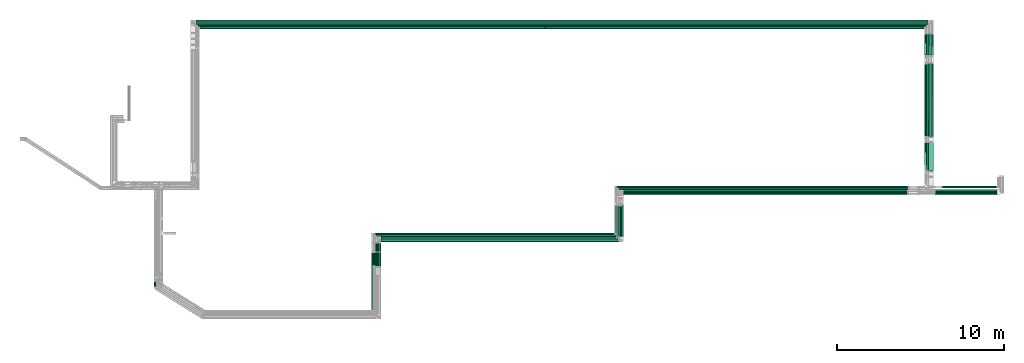
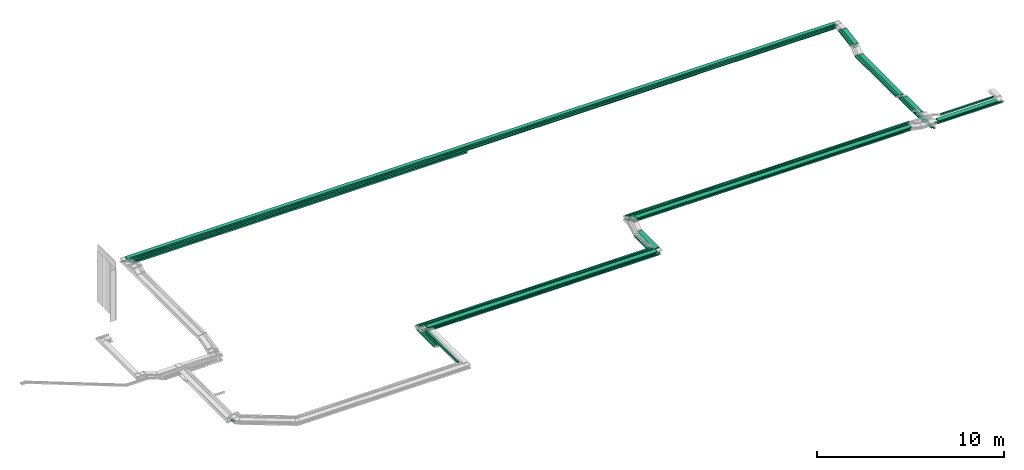
# One storey, part 2 of 18: 51 flow segments.
"""IFC2X3 building model written with IfcOpenShell, lengths in millimetres."""

from ifc_helpers import new_model, entity, si_unit, converted_unit, derived_unit, direction, frame, frame_2d, origin, origin_2d_with_axis, place, context, subcontext, project, spatial, rectangle, extrude, type_object, element, save


model = new_model("IFC2X3")

# Units and contexts
model_context = context("Model", 3, precision=0.01, world=origin(), true_north=direction((6.12303176911189e-17, 1.0)))
body_context = subcontext(model_context, "Body", "Model", "MODEL_VIEW")
ifc_project = project(units=[si_unit("LENGTHUNIT", "METRE", prefix="MILLI"), si_unit("AREAUNIT", "SQUARE_METRE"), si_unit("VOLUMEUNIT", "CUBIC_METRE"), converted_unit("PLANEANGLEUNIT", "DEGREE", entity("IfcRatioMeasure", 0.0174532925199433), si_unit("PLANEANGLEUNIT", "RADIAN"), dimensions=[0, 0, 0, 0, 0, 0, 0]), si_unit("MASSUNIT", "GRAM", prefix="KILO"), derived_unit("MASSDENSITYUNIT", [(si_unit("MASSUNIT", "GRAM", prefix="KILO"), 1), (si_unit("LENGTHUNIT", "METRE"), -3)]), derived_unit("MOMENTOFINERTIAUNIT", [(si_unit("LENGTHUNIT", "METRE"), 4)]), si_unit("TIMEUNIT", "SECOND"), si_unit("FREQUENCYUNIT", "HERTZ"), si_unit("THERMODYNAMICTEMPERATUREUNIT", "DEGREE_CELSIUS"), derived_unit("THERMALTRANSMITTANCEUNIT", [(si_unit("MASSUNIT", "GRAM", prefix="KILO"), 1), (si_unit("THERMODYNAMICTEMPERATUREUNIT", "KELVIN"), -1), (si_unit("TIMEUNIT", "SECOND"), -3)]), derived_unit("VOLUMETRICFLOWRATEUNIT", [(si_unit("LENGTHUNIT", "METRE"), 3), (si_unit("TIMEUNIT", "SECOND"), -1)]), derived_unit("MASSFLOWRATEUNIT", [(si_unit("MASSUNIT", "GRAM", prefix="KILO"), 1), (si_unit("TIMEUNIT", "SECOND"), -1)]), derived_unit("ROTATIONALFREQUENCYUNIT", [(si_unit("TIMEUNIT", "SECOND"), -1)]), si_unit("ELECTRICCURRENTUNIT", "AMPERE"), si_unit("ELECTRICVOLTAGEUNIT", "VOLT"), si_unit("POWERUNIT", "WATT"), si_unit("FORCEUNIT", "NEWTON", prefix="KILO"), si_unit("ILLUMINANCEUNIT", "LUX"), si_unit("LUMINOUSFLUXUNIT", "LUMEN"), si_unit("LUMINOUSINTENSITYUNIT", "CANDELA"), derived_unit("USERDEFINED", [(si_unit("MASSUNIT", "GRAM", prefix="KILO"), -1), (si_unit("LENGTHUNIT", "METRE"), -2), (si_unit("TIMEUNIT", "SECOND"), 3), (si_unit("LUMINOUSFLUXUNIT", "LUMEN"), 1)]), derived_unit("LINEARVELOCITYUNIT", [(si_unit("LENGTHUNIT", "METRE"), 1), (si_unit("TIMEUNIT", "SECOND"), -1)]), si_unit("PRESSUREUNIT", "PASCAL"), derived_unit("USERDEFINED", [(si_unit("LENGTHUNIT", "METRE"), -2), (si_unit("MASSUNIT", "GRAM", prefix="KILO"), 1), (si_unit("TIMEUNIT", "SECOND"), -2)]), derived_unit("LINEARFORCEUNIT", [(si_unit("MASSUNIT", "GRAM", prefix="KILO"), 1), (si_unit("LENGTHUNIT", "METRE"), 1), (si_unit("TIMEUNIT", "SECOND"), -2), (si_unit("LENGTHUNIT", "METRE"), -1)]), derived_unit("PLANARFORCEUNIT", [(si_unit("MASSUNIT", "GRAM", prefix="KILO"), 1), (si_unit("LENGTHUNIT", "METRE"), 1), (si_unit("TIMEUNIT", "SECOND"), -2), (si_unit("LENGTHUNIT", "METRE"), -2)])], contexts=[model_context])

# Site, building, storey
site_placement = place(None, frame((0.0, -0.00077364408347762, 0.0)))
site = spatial("IfcSite", under=ifc_project, at=site_placement, CompositionType="ELEMENT")
building_placement = place(site_placement, origin())
building = spatial("IfcBuilding", under=site, at=building_placement, CompositionType="ELEMENT")
storey_placement = place(building_placement, frame((0.0, 0.0, 19800.0)))
storey = spatial("IfcBuildingStorey", under=building, at=storey_placement, CompositionType="ELEMENT", Elevation=19800.0)

# Flow segments
cable_carrier_segment_type = type_object("IfcCableCarrierSegmentType", PredefinedType="CABLETRAYSEGMENT")
flow_segment_1_placement = place(storey_placement, frame((20510.216800265, 19700.0006393667, 3299.99856456245)))
element("IfcFlowSegment", 1, at=flow_segment_1_placement, inside=storey, type_object=cable_carrier_segment_type, context=body_context, shape_type="SweptSolid", body=[
    extrude(rectangle(XDim=43861.6970823392, YDim=300.000000000001, at=frame_2d((-3.63797880709171e-12, 2.17426077142591e-12), x_axis=(1.0, 0.0))), frame((21930.8485411696, 150.0, 0.000717718780356336), z_axis=(3.27264479763197e-08, 0.0, 1.0), x_axis=(-1.0, 0.0, 3.27264479763197e-08)), (0.0, 0.0, 1.0), 49.9999999999973),
])
flow_segment_2_placement = place(storey_placement, frame((20615.2168010831, 19595.0006393667, 3300.0)))
element("IfcFlowSegment", 2, at=flow_segment_2_placement, inside=storey, type_object=cable_carrier_segment_type, context=body_context, shape_type="SweptSolid", body=[
    extrude(rectangle(XDim=43650.3107133575, YDim=100.000000000003, at=frame_2d((-5.45696821063757e-12, -2.16715534406831e-12), x_axis=(1.0, 0.0))), frame((21825.1553566787, 50.0, 0.0), z_axis=(0.0, 0.0, 1.0), x_axis=(-1.0, 0.0, 0.0)), (0.0, 0.0, 1.0), 100.000000000003),
])
flow_segment_3_placement = place(storey_placement, frame((20720.2168010831, 19490.0006393667, 3300.0)))
element("IfcFlowSegment", 3, at=flow_segment_3_placement, inside=storey, type_object=cable_carrier_segment_type, context=body_context, shape_type="SweptSolid", body=[
    extrude(rectangle(XDim=43439.8425431613, YDim=100.000000000001, at=frame_2d((3.63797880709171e-12, -1.08357767203415e-12), x_axis=(1.0, 0.0))), frame((21719.9212715806, 50.0, 0.0), z_axis=(0.0, 0.0, 1.0), x_axis=(-1.0, 0.0, 0.0)), (0.0, 0.0, 1.0), 100.000000000003),
])
flow_segment_4_placement = place(storey_placement, frame((64593.0376989449, 9615.00063936669, 2550.0)))
element("IfcFlowSegment", 4, at=flow_segment_4_placement, inside=storey, type_object=cable_carrier_segment_type, context=body_context, shape_type="SweptSolid", body=[
    extrude(rectangle(XDim=7760.0992906484, YDim=99.9999999999946, at=frame_2d((0.0, -4.33075797445781e-12), x_axis=(1.0, 0.0))), frame((50.0, 3880.0496453242, 0.0), z_axis=(0.0, 0.0, 1.0), x_axis=(0.0, -1.0, 0.0)), (0.0, 0.0, 1.0), 49.9999999999973),
])
flow_segment_5_placement = place(storey_placement, frame((64490.5275144406, 9720.00063936033, 2550.0)))
element("IfcFlowSegment", 5, at=flow_segment_5_placement, inside=storey, type_object=cable_carrier_segment_type, context=body_context, shape_type="SweptSolid", body=[
    extrude(rectangle(XDim=7655.09929065903, YDim=99.9999999999946, at=frame_2d((0.0, -4.33075797445781e-12), x_axis=(1.0, 0.0))), frame((50.0, 3827.54964532952, 0.0), z_axis=(0.0, 0.0, 1.0), x_axis=(0.0, -1.0, 0.0)), (0.0, 0.0, 1.0), 49.9999999999973),
])
flow_segment_6_placement = place(storey_placement, frame((64388.5726926723, 10290.0006393667, 2550.0)))
element("IfcFlowSegment", 6, at=flow_segment_6_placement, inside=storey, type_object=cable_carrier_segment_type, context=body_context, shape_type="SweptSolid", body=[
    extrude(rectangle(XDim=7085.0992906527, YDim=99.9999999999946, at=frame_2d((-9.09494701772928e-13, 0.0), x_axis=(1.0, 0.0))), frame((50.0, 3542.54964532635, 0.0), z_axis=(0.0, 0.0, 1.0), x_axis=(0.0, -1.0, 0.0)), (0.0, 0.0, 1.0), 49.9999999999973),
])
flow_segment_7_placement = place(storey_placement, frame((20720.2168010831, 19490.0006393668, 3100.0)))
element("IfcFlowSegment", 7, at=flow_segment_7_placement, inside=storey, type_object=cable_carrier_segment_type, context=body_context, shape_type="SweptSolid", body=[
    extrude(rectangle(XDim=20698.7834674717, YDim=100.000000000001, at=frame_2d((0.0, 1.08357767203415e-12), x_axis=(1.0, 0.0))), frame((10349.3917337358, 50.0, 0.0), z_axis=(0.0, 0.0, 1.0), x_axis=(-1.0, 0.0, 0.0)), (0.0, 0.0, 1.0), 100.000000000003),
])
flow_segment_8_placement = place(storey_placement, frame((20310.2168010831, 19900.0006393667, 3100.0)))
element("IfcFlowSegment", 8, at=flow_segment_8_placement, inside=storey, type_object=cable_carrier_segment_type, context=body_context, shape_type="SweptSolid", body=[
    extrude(rectangle(XDim=44262.8208978618, YDim=100.000000000003, at=frame_2d((0.0, 2.16715534406831e-12), x_axis=(1.0, 0.0))), frame((22131.4104489309, 50.0, 0.0), z_axis=(0.0, 0.0, 1.0), x_axis=(-1.0, 0.0, 0.0)), (0.0, 0.0, 1.0), 49.9999999999973),
])
flow_segment_9_placement = place(storey_placement, frame((20415.2168010831, 19795.0006393667, 3100.0)))
element("IfcFlowSegment", 9, at=flow_segment_9_placement, inside=storey, type_object=cable_carrier_segment_type, context=body_context, shape_type="SweptSolid", body=[
    extrude(rectangle(XDim=44055.3107133575, YDim=100.000000000003, at=frame_2d((-3.63797880709171e-12, 2.16715534406831e-12), x_axis=(1.0, 0.0))), frame((22027.6553566787, 50.0, 0.0), z_axis=(0.0, 0.0, 1.0), x_axis=(-1.0, 0.0, 0.0)), (0.0, 0.0, 1.0), 49.9999999999973),
])
flow_segment_10_placement = place(storey_placement, frame((20520.2168010831, 19690.0006393667, 3100.0)))
element("IfcFlowSegment", 10, at=flow_segment_10_placement, inside=storey, type_object=cable_carrier_segment_type, context=body_context, shape_type="SweptSolid", body=[
    extrude(rectangle(XDim=43848.3558915892, YDim=100.000000000003, at=frame_2d((0.0, 2.16715534406831e-12), x_axis=(1.0, 0.0))), frame((21924.1779457946, 50.0, 0.0), z_axis=(0.0, 0.0, 1.0), x_axis=(-1.0, 0.0, 0.0)), (0.0, 0.0, 1.0), 49.9999999999973),
])
flow_segment_11_placement = place(storey_placement, frame((46136.3862833498, 9515.00005292883, 3174.99999031633)))
element("IfcFlowSegment", 11, at=flow_segment_11_placement, inside=storey, type_object=cable_carrier_segment_type, context=body_context, shape_type="SweptSolid", body=[
    extrude(rectangle(XDim=17012.5626625772, YDim=300.000000000001, at=frame_2d((4.54747350886464e-12, 0.0), x_axis=(1.0, 0.0))), frame((8506.2813312886, 150.0, 1.41768531420894e-05), z_axis=(0.0, 6.09869900927148e-08, 1.0), x_axis=(-1.0, 0.0, 0.0)), (0.0, 0.0, 1.0), 50.0000000000017),
])
flow_segment_12_placement = place(storey_placement, frame((45715.1221386505, 9945.00008284563, 3175.0)))
element("IfcFlowSegment", 12, at=flow_segment_12_placement, inside=storey, type_object=cable_carrier_segment_type, context=body_context, shape_type="SweptSolid", body=[
    extrude(rectangle(XDim=17558.63871242, YDim=99.9999999999989, at=origin_2d_with_axis()), frame((8779.31935621001, 50.0, 0.0), z_axis=(0.0, 0.0, 1.0), x_axis=(-1.0, 0.0, 0.0)), (0.0, 0.0, 1.0), 100.000000000003),
])
flow_segment_13_placement = place(storey_placement, frame((31591.4335639594, 6717.77902723853, 2800.0)))
element("IfcFlowSegment", 13, at=flow_segment_13_placement, inside=storey, type_object=cable_carrier_segment_type, context=body_context, shape_type="SweptSolid", body=[
    extrude(rectangle(XDim=14204.952720189, YDim=300.000000000001, at=origin_2d_with_axis()), frame((7102.47636009451, 150.0, 0.0), z_axis=(0.0, 0.0, 1.0), x_axis=(-1.0, 0.0, 0.0)), (0.0, 0.0, 1.0), 49.9999999999973),
])
flow_segment_14_placement = place(storey_placement, frame((31280.6071314255, 7021.9281801225, 2800.0)))
element("IfcFlowSegment", 14, at=flow_segment_14_placement, inside=storey, type_object=cable_carrier_segment_type, context=body_context, shape_type="SweptSolid", body=[
    extrude(rectangle(XDim=14408.678815753, YDim=100.000000000001, at=frame_2d((0.0, -5.43565192856477e-13), x_axis=(1.0, 0.0))), frame((7204.33940787652, 50.0, 0.0), z_axis=(0.0, 0.0, 1.0), x_axis=(-1.0, 0.0, 0.0)), (0.0, 0.0, 1.0), 100.000000000003),
])
flow_segment_15_placement = place(storey_placement, frame((31167.8922149001, 7125.0, 2800.0)))
element("IfcFlowSegment", 15, at=flow_segment_15_placement, inside=storey, type_object=cable_carrier_segment_type, context=body_context, shape_type="SweptSolid", body=[
    extrude(rectangle(XDim=14407.2299237504, YDim=100.000000000001, at=frame_2d((-4.54747350886464e-12, -5.43565192856477e-13), x_axis=(1.0, 0.0))), frame((7203.6149618752, 50.0, 0.0), z_axis=(0.0, 0.0, 1.0), x_axis=(-1.0, 0.0, 0.0)), (0.0, 0.0, 1.0), 100.000000000003),
])
flow_segment_16_placement = place(storey_placement, frame((31591.4335639594, 6717.77902723852, 2600.0)))
element("IfcFlowSegment", 16, at=flow_segment_16_placement, inside=storey, type_object=cable_carrier_segment_type, context=body_context, shape_type="SweptSolid", body=[
    extrude(rectangle(XDim=14323.3274230858, YDim=99.9999999999989, at=frame_2d((-2.27373675443232e-12, 5.40012479177676e-13), x_axis=(1.0, 0.0))), frame((7161.66371154289, 50.0, 0.0), z_axis=(0.0, 0.0, 1.0), x_axis=(-1.0, 0.0, 0.0)), (0.0, 0.0, 1.0), 50.0000000000016),
])
flow_segment_17_placement = place(storey_placement, frame((31481.4991593832, 6822.77902723852, 2600.0)))
element("IfcFlowSegment", 17, at=flow_segment_17_placement, inside=storey, type_object=cable_carrier_segment_type, context=body_context, shape_type="SweptSolid", body=[
    extrude(rectangle(XDim=14320.0, YDim=99.9999999999989, at=frame_2d((2.27373675443232e-12, 0.0), x_axis=(1.0, 0.0))), frame((7160.0, 50.0, 0.0), z_axis=(0.0, 0.0, 1.0), x_axis=(-1.0, 0.0, 0.0)), (0.0, 0.0, 1.0), 49.9999999999973),
])
flow_segment_18_placement = place(storey_placement, frame((31369.2859471786, 6927.77902723852, 2600.0)))
element("IfcFlowSegment", 18, at=flow_segment_18_placement, inside=storey, type_object=cable_carrier_segment_type, context=body_context, shape_type="SweptSolid", body=[
    extrude(rectangle(XDim=14320.0, YDim=99.9999999999989, at=frame_2d((2.27373675443232e-12, 5.40012479177676e-13), x_axis=(1.0, 0.0))), frame((7160.0, 50.0, 0.0), z_axis=(0.0, 0.0, 1.0), x_axis=(-1.0, 0.0, 0.0)), (0.0, 0.0, 1.0), 49.9999999999973),
])
flow_segment_19_placement = place(storey_placement, frame((31245.1088789037, 7125.0, 2600.0)))
element("IfcFlowSegment", 19, at=flow_segment_19_placement, inside=storey, type_object=cable_carrier_segment_type, context=body_context, shape_type="SweptSolid", body=[
    extrude(rectangle(XDim=14330.0132597468, YDim=99.9999999999989, at=frame_2d((1.81898940354586e-12, -1.08357767203415e-12), x_axis=(1.0, 0.0))), frame((7165.00662987341, 50.0, 0.0), z_axis=(0.0, 0.0, 1.0), x_axis=(-1.0, 0.0, 0.0)), (0.0, 0.0, 1.0), 100.000000000003),
])
flow_segment_20_placement = place(storey_placement, frame((64391.9138834223, 17890.7715456811, 3082.61086731143)))
element("IfcFlowSegment", 20, at=flow_segment_20_placement, inside=storey, type_object=cable_carrier_segment_type, context=body_context, shape_type="SweptSolid", body=[
    extrude(rectangle(XDim=49.9999999999963, YDim=1283.81748851725, at=frame_2d((-1.08002495835535e-12, 1.86517468137026e-13), x_axis=(0.0, 1.0))), frame((0.0, 636.956556995006, 132.702158056389), z_axis=(1.0, 0.0, 0.0), x_axis=(0.0, -0.985728987268031, -0.168340023938282)), (0.0, 0.0, 1.0), 300.000000000001),
])
flow_segment_21_placement = place(storey_placement, frame((64285.5275144406, 17888.8603400682, 3083.36144550776)))
element("IfcFlowSegment", 21, at=flow_segment_21_placement, inside=storey, type_object=cable_carrier_segment_type, context=body_context, shape_type="SweptSolid", body=[
    extrude(rectangle(XDim=100.000000000001, YDim=99.9999999999946, at=frame_2d((-1.81188397618826e-13, 0.0), x_axis=(1.0, 0.0))), frame((50.0, 8.41700119691529, 49.2864493634023), z_axis=(0.0, 0.985728987268031, 0.168340023938282), x_axis=(0.0, -0.168340023938282, 0.985728987268031)), (0.0, 0.0, 1.0), 1277.24793927283),
])
flow_segment_22_placement = place(storey_placement, frame((64180.0593442443, 17888.8603400682, 3083.36144550776)))
element("IfcFlowSegment", 22, at=flow_segment_22_placement, inside=storey, type_object=cable_carrier_segment_type, context=body_context, shape_type="SweptSolid", body=[
    extrude(rectangle(XDim=100.000000000001, YDim=99.9999999999946, at=frame_2d((-1.81188397618826e-13, 0.0), x_axis=(1.0, 0.0))), frame((50.0, 8.41700119691313, 49.2864493634066), z_axis=(0.0, 0.985728987268031, 0.168340023938282), x_axis=(0.0, -0.168340023938282, 0.985728987268031)), (0.0, 0.0, 1.0), 1277.24793927283),
])
for number, where in (
    (23, (64593.0376989449, 17882.6287228456, 2877.80619248528)),
    (24, (64490.5275144406, 17882.6287228456, 2877.80619248528)),
    (25, (64388.5726926723, 17882.6287228456, 2877.80619248528)),
):
    element("IfcFlowSegment", number, at=place(storey_placement, frame(where)), inside=storey, type_object=cable_carrier_segment_type, context=body_context, shape_type="SweptSolid", body=[
        extrude(rectangle(XDim=49.9999999999963, YDim=1312.36750384491, at=frame_2d((0.0, 0.0), x_axis=(0.0, 1.0))), frame((0.0, 651.027845842717, 135.10521318823), z_axis=(1.0, 0.0, 0.0), x_axis=(0.0, -0.985728987268033, -0.168340023938271)), (0.0, 0.0, 1.0), 99.9999999999945),
    ])
flow_segment_23_placement = place(storey_placement, frame((64285.5467024828, 10981.4942885013, 2800.00365146292)))
element("IfcFlowSegment", 26, at=flow_segment_23_placement, inside=storey, type_object=cable_carrier_segment_type, context=body_context, shape_type="SweptSolid", body=[
    extrude(rectangle(XDim=1669.27622341284, YDim=99.999999999908, at=frame_2d((0.0, -4.33075797445781e-12), x_axis=(1.0, 0.0))), frame((50.0, 834.649123727306, 0.0919527997453315), z_axis=(0.0, -0.000110170861433383, 0.999999993931191), x_axis=(0.0, 0.999999993931191, 0.000110170861433383)), (0.0, 0.0, 1.0), 99.9999999999068),
])
flow_segment_24_placement = place(storey_placement, frame((64180.0597687348, 11289.128001488, 2800.00494189321)))
element("IfcFlowSegment", 27, at=flow_segment_24_placement, inside=storey, type_object=cable_carrier_segment_type, context=body_context, shape_type="SweptSolid", body=[
    extrude(rectangle(XDim=1361.64006742099, YDim=99.9999999999946, at=origin_2d_with_axis()), frame((50.0, 680.833403180097, 0.0910634902381617), z_axis=(0.0, -0.000133755597263879, 0.99999999105472), x_axis=(0.0, 0.99999999105472, 0.000133755597263879)), (0.0, 0.0, 1.0), 99.9999999999964),
])
flow_segment_25_placement = place(storey_placement, frame((64393.0376989449, 10968.0961382918, 2800.0)))
element("IfcFlowSegment", 28, at=flow_segment_25_placement, inside=storey, type_object=cable_carrier_segment_type, context=body_context, shape_type="SweptSolid", body=[
    extrude(rectangle(XDim=1687.04298934208, YDim=300.000000000001, at=frame_2d((-1.08002495835535e-12, 0.0), x_axis=(1.0, 0.0))), frame((150.0, 843.52149467104, 0.0), z_axis=(0.0, 0.0, 1.0), x_axis=(0.0, 1.0, 0.0)), (0.0, 0.0, 1.0), 49.9999999999973),
])
flow_segment_26_placement = place(storey_placement, frame((45595.1221386505, 7245.0, 2600.0)))
element("IfcFlowSegment", 29, at=flow_segment_26_placement, inside=storey, type_object=cable_carrier_segment_type, context=body_context, shape_type="SweptSolid", body=[
    extrude(rectangle(XDim=1580.56637967652, YDim=99.9999999999946, at=frame_2d((-5.6843418860808e-13, 0.0), x_axis=(1.0, 0.0))), frame((50.0, 790.28318983826, 0.0), z_axis=(0.0, 0.0, 1.0), x_axis=(0.0, 1.0, 0.0)), (0.0, 0.0, 1.0), 100.000000000003),
])
flow_segment_27_placement = place(storey_placement, frame((45709.2859471786, 7047.77902723852, 2600.0)))
element("IfcFlowSegment", 30, at=flow_segment_27_placement, inside=storey, type_object=cable_carrier_segment_type, context=body_context, shape_type="SweptSolid", body=[
    extrude(rectangle(XDim=1790.25375258002, YDim=99.9999999999946, at=origin_2d_with_axis()), frame((50.0, 895.126876290009, 0.0), z_axis=(0.0, 0.0, 1.0), x_axis=(0.0, 1.0, 0.0)), (0.0, 0.0, 1.0), 49.999999999993),
])
flow_segment_28_placement = place(storey_placement, frame((45821.4991593832, 6942.77902723852, 2600.0)))
element("IfcFlowSegment", 31, at=flow_segment_28_placement, inside=storey, type_object=cable_carrier_segment_type, context=body_context, shape_type="SweptSolid", body=[
    extrude(rectangle(XDim=1895.25375258002, YDim=99.9999999999946, at=frame_2d((0.0, 4.33075797445781e-12), x_axis=(1.0, 0.0))), frame((50.0, 947.626876290012, 0.0), z_axis=(0.0, 0.0, 1.0), x_axis=(0.0, 1.0, 0.0)), (0.0, 0.0, 1.0), 50.0000000000016),
])
flow_segment_29_placement = place(storey_placement, frame((45934.7609870451, 6837.77902723851, 2600.0)))
element("IfcFlowSegment", 32, at=flow_segment_29_placement, inside=storey, type_object=cable_carrier_segment_type, context=body_context, shape_type="SweptSolid", body=[
    extrude(rectangle(XDim=2000.25375258002, YDim=99.9999999999946, at=origin_2d_with_axis()), frame((50.0, 1000.12687629001, 0.0), z_axis=(0.0, 0.0, 1.0), x_axis=(0.0, 1.0, 0.0)), (0.0, 0.0, 1.0), 49.999999999993),
])
flow_segment_30_placement = place(storey_placement, frame((45816.3862841484, 7037.77902723852, 2800.0)))
element("IfcFlowSegment", 33, at=flow_segment_30_placement, inside=storey, type_object=cable_carrier_segment_type, context=body_context, shape_type="SweptSolid", body=[
    extrude(rectangle(XDim=1884.43926960423, YDim=300.000000000001, at=frame_2d((0.0, -4.33431068813661e-12), x_axis=(1.0, 0.0))), frame((150.0, 942.219634802116, 0.0), z_axis=(0.0, 0.0, 1.0), x_axis=(0.0, 1.0, 0.0)), (0.0, 0.0, 1.0), 49.9999999999973),
])
flow_segment_31_placement = place(storey_placement, frame((31125.1088789037, 5296.63362492178, 2600.0)))
element("IfcFlowSegment", 34, at=flow_segment_31_placement, inside=storey, type_object=cable_carrier_segment_type, context=body_context, shape_type="SweptSolid", body=[
    extrude(rectangle(XDim=1808.36637507826, YDim=100.000000000003, at=origin_2d_with_axis()), frame((50.0, 904.183187539129, 0.0), z_axis=(0.0, 0.0, 1.0), x_axis=(0.0, 1.0, 0.0)), (0.0, 0.0, 1.0), 100.000000000003),
])
flow_segment_32_placement = place(storey_placement, frame((31249.2859471786, 5245.16498530927, 2600.0)))
element("IfcFlowSegment", 35, at=flow_segment_32_placement, inside=storey, type_object=cable_carrier_segment_type, context=body_context, shape_type="SweptSolid", body=[
    extrude(rectangle(XDim=1662.61404192942, YDim=100.000000000003, at=frame_2d((-5.6843418860808e-13, -4.33431068813661e-12), x_axis=(1.0, 0.0))), frame((50.0, 831.307020964711, 0.0), z_axis=(0.0, 0.0, 1.0), x_axis=(0.0, -1.0, 0.0)), (0.0, 0.0, 1.0), 49.9999999999973),
])
flow_segment_33_placement = place(storey_placement, frame((31361.4991593832, 5245.16498530928, 2600.0)))
element("IfcFlowSegment", 36, at=flow_segment_33_placement, inside=storey, type_object=cable_carrier_segment_type, context=body_context, shape_type="SweptSolid", body=[
    extrude(rectangle(XDim=1557.61404192941, YDim=100.000000000003, at=frame_2d((-5.6843418860808e-13, 2.16715534406831e-12), x_axis=(1.0, 0.0))), frame((50.0, 778.807020964705, 0.0), z_axis=(0.0, 0.0, 1.0), x_axis=(0.0, -1.0, 0.0)), (0.0, 0.0, 1.0), 49.9999999999973),
])
flow_segment_34_placement = place(storey_placement, frame((31471.4335639594, 5245.16498530928, 2600.0)))
element("IfcFlowSegment", 37, at=flow_segment_34_placement, inside=storey, type_object=cable_carrier_segment_type, context=body_context, shape_type="SweptSolid", body=[
    extrude(rectangle(XDim=1452.61404192941, YDim=100.000000000003, at=frame_2d((-5.11590769747272e-13, 0.0), x_axis=(1.0, 0.0))), frame((50.0, 726.307020964705, 0.0), z_axis=(0.0, 0.0, 1.0), x_axis=(0.0, -1.0, 0.0)), (0.0, 0.0, 1.0), 49.9999999999973),
])
flow_segment_35_placement = place(storey_placement, frame((31047.8922149002, 2619.99989830113, 3200.0)))
element("IfcFlowSegment", 38, at=flow_segment_35_placement, inside=storey, type_object=cable_carrier_segment_type, context=body_context, shape_type="SweptSolid", body=[
    extrude(rectangle(XDim=3419.24047842777, YDim=100.000000000003, at=origin_2d_with_axis()), frame((50.0, 1709.62023921389, 0.0), z_axis=(0.0, 0.0, 1.0), x_axis=(0.0, 1.0, 0.0)), (0.0, 0.0, 1.0), 100.000000000008),
])
flow_segment_36_placement = place(storey_placement, frame((18007.1440474966, 4020.34867137986, 3000.0)))
element("IfcFlowSegment", 39, at=flow_segment_36_placement, inside=storey, type_object=cable_carrier_segment_type, context=body_context, shape_type="SweptSolid", body=[
    extrude(rectangle(XDim=303.89022785907, YDim=99.9999999999989, at=frame_2d((0.0, -1.08357767203415e-12), x_axis=(1.0, 0.0))), frame((50.0, 151.945113929536, 0.0), z_axis=(0.0, 0.0, 1.0), x_axis=(0.0, 1.0, 0.0)), (0.0, 0.0, 1.0), 49.9999999999973),
])
flow_segment_37_placement = place(storey_placement, frame((64823.0376989449, 9615.00008284603, 2800.0)))
element("IfcFlowSegment", 40, at=flow_segment_37_placement, inside=storey, type_object=cable_carrier_segment_type, context=body_context, shape_type="SweptSolid", body=[
    extrude(rectangle(XDim=3987.54391835811, YDim=100.000000000001, at=origin_2d_with_axis()), frame((1993.77195917906, 50.0, 0.0)), (0.0, 0.0, 1.0), 49.9999999999973),
])
flow_segment_38_placement = place(storey_placement, frame((64720.5275144406, 9720.00008284602, 2800.0)))
element("IfcFlowSegment", 41, at=flow_segment_38_placement, inside=storey, type_object=cable_carrier_segment_type, context=body_context, shape_type="SweptSolid", body=[
    extrude(rectangle(XDim=3976.91068107751, YDim=99.9999999999989, at=origin_2d_with_axis()), frame((1988.45534053876, 50.0, 0.0)), (0.0, 0.0, 1.0), 49.9999999999973),
])
flow_segment_39_placement = place(storey_placement, frame((65228.9608075319, 9945.00008284604, 3000.0)))
element("IfcFlowSegment", 42, at=flow_segment_39_placement, inside=storey, type_object=cable_carrier_segment_type, context=body_context, shape_type="SweptSolid", body=[
    extrude(rectangle(XDim=3274.30346905501, YDim=99.9999999999989, at=frame_2d((-4.32009983342141e-12, 0.0), x_axis=(1.0, 0.0))), frame((1637.15173452751, 50.0, 0.0)), (0.0, 0.0, 1.0), 100.000000000003),
])
flow_segment_40_placement = place(storey_placement, frame((45829.2859473371, 9836.00006193248, 3174.99999050108)))
element("IfcFlowSegment", 43, at=flow_segment_40_placement, inside=storey, type_object=cable_carrier_segment_type, context=body_context, shape_type="SweptSolid", body=[
    extrude(rectangle(XDim=17320.17589421, YDim=100.000000000001, at=frame_2d((0.0, 1.08357767203415e-12), x_axis=(1.0, 0.0))), frame((8660.08794729364, 50.0, 2.6520901690219e-05), z_axis=(-1.88655445451045e-09, 2.03663483944181e-07, 1.0), x_axis=(-1.0, 0.0, -1.8865544545043e-09)), (0.0, 0.0, 1.0), 99.9999999999967),
])
flow_segment_41_placement = place(storey_placement, frame((45715.1221386505, 9945.00008284604, 2950.0)))
element("IfcFlowSegment", 44, at=flow_segment_41_placement, inside=storey, type_object=cable_carrier_segment_type, context=body_context, shape_type="SweptSolid", body=[
    extrude(rectangle(XDim=17434.9052265142, YDim=99.9999999999989, at=frame_2d((0.0, -1.08357767203415e-12), x_axis=(1.0, 0.0))), frame((8717.45261325709, 50.0, 0.0), z_axis=(0.0, 0.0, 1.0), x_axis=(-1.0, 0.0, 0.0)), (0.0, 0.0, 1.0), 100.000000000003),
])
flow_segment_42_placement = place(storey_placement, frame((45829.2859471785, 9825.00008284607, 2950.0)))
element("IfcFlowSegment", 45, at=flow_segment_42_placement, inside=storey, type_object=cable_carrier_segment_type, context=body_context, shape_type="SweptSolid", body=[
    extrude(rectangle(XDim=17326.3300603298, YDim=99.9999999999989, at=frame_2d((0.0, -1.08357767203415e-12), x_axis=(1.0, 0.0))), frame((8663.16503016491, 50.0, 0.0), z_axis=(0.0, 0.0, 1.0), x_axis=(-1.0, 0.0, 0.0)), (0.0, 0.0, 1.0), 49.9999999999973),
])
flow_segment_43_placement = place(storey_placement, frame((45941.4991593832, 9720.00008284579, 2950.0)))
element("IfcFlowSegment", 46, at=flow_segment_43_placement, inside=storey, type_object=cable_carrier_segment_type, context=body_context, shape_type="SweptSolid", body=[
    extrude(rectangle(XDim=17216.2477546201, YDim=99.9999999999989, at=frame_2d((0.0, -1.08357767203415e-12), x_axis=(1.0, 0.0))), frame((8608.12387731003, 50.0, 0.0), z_axis=(0.0, 0.0, 1.0), x_axis=(-1.0, 0.0, 0.0)), (0.0, 0.0, 1.0), 49.9999999999973),
])
flow_segment_44_placement = place(storey_placement, frame((46054.7609870451, 9615.00008284604, 2950.0)))
element("IfcFlowSegment", 47, at=flow_segment_44_placement, inside=storey, type_object=cable_carrier_segment_type, context=body_context, shape_type="SweptSolid", body=[
    extrude(rectangle(XDim=17117.3462182917, YDim=100.000000000001, at=frame_2d((0.0, 5.43565192856477e-13), x_axis=(1.0, 0.0))), frame((8558.67310914585, 50.0, 0.0), z_axis=(0.0, 0.0, 1.0), x_axis=(-1.0, 0.0, 0.0)), (0.0, 0.0, 1.0), 49.9999999999973),
])
flow_segment_45_placement = place(storey_placement, frame((64391.9201223101, 13008.6257980895, 2700.0)))
element("IfcFlowSegment", 48, at=flow_segment_45_placement, inside=storey, type_object=cable_carrier_segment_type, context=body_context, shape_type="SweptSolid", body=[
    extrude(rectangle(XDim=4374.71884293394, YDim=300.000000000004, at=frame_2d((0.0, -4.32009983342141e-12), x_axis=(1.0, 0.0))), frame((150.557102382143, 2187.39755461602, 0.0), z_axis=(0.0, 0.0, 1.0), x_axis=(0.000254693966544882, -0.999999967565491, 0.0)), (0.0, 0.0, 1.0), 49.999999999993),
])
flow_segment_46_placement = place(storey_placement, frame((64285.5467025618, 13019.2518823208, 2700.18983718397)))
element("IfcFlowSegment", 49, at=flow_segment_46_placement, inside=storey, type_object=cable_carrier_segment_type, context=body_context, shape_type="SweptSolid", body=[
    extrude(rectangle(XDim=4338.3016544712, YDim=99.999999841948, at=frame_2d((0.0, -4.33431068813661e-12), x_axis=(1.0, 0.0))), frame((50.0, 2169.15085367438, 0.000573498715721144), z_axis=(0.0, -2.64388587007212e-07, 1.0), x_axis=(0.0, 1.0, 2.64388587007212e-07)), (0.0, 0.0, 1.0), 99.9999998419428),
])
flow_segment_47_placement = place(storey_placement, frame((64180.0593483128, 13019.2518907177, 2700.18983710494)))
element("IfcFlowSegment", 50, at=flow_segment_47_placement, inside=storey, type_object=cable_carrier_segment_type, context=body_context, shape_type="SweptSolid", body=[
    extrude(rectangle(XDim=4338.30020865616, YDim=99.9999999999951, at=frame_2d((1.13686837721616e-12, 0.0), x_axis=(1.0, 0.0))), frame((50.0002092131146, 2169.15010915053, 0.0), z_axis=(0.0, 0.0, 1.0), x_axis=(-9.64493498738689e-08, 1.0, 0.0)), (0.0, 0.0, 1.0), 100.000000000003),
])
flow_segment_48_placement = place(storey_placement, frame((64823.0376989449, 9515.00008284601, 3000.0)))
element("IfcFlowSegment", 51, at=flow_segment_48_placement, inside=storey, type_object=cable_carrier_segment_type, context=body_context, shape_type="SweptSolid", body=[
    extrude(rectangle(XDim=3679.75388627882, YDim=300.000000000001, at=origin_2d_with_axis()), frame((1839.87694313941, 150.0, 0.0)), (0.0, 0.0, 1.0), 49.9999999999973),
])

save(model, "model.ifc")
